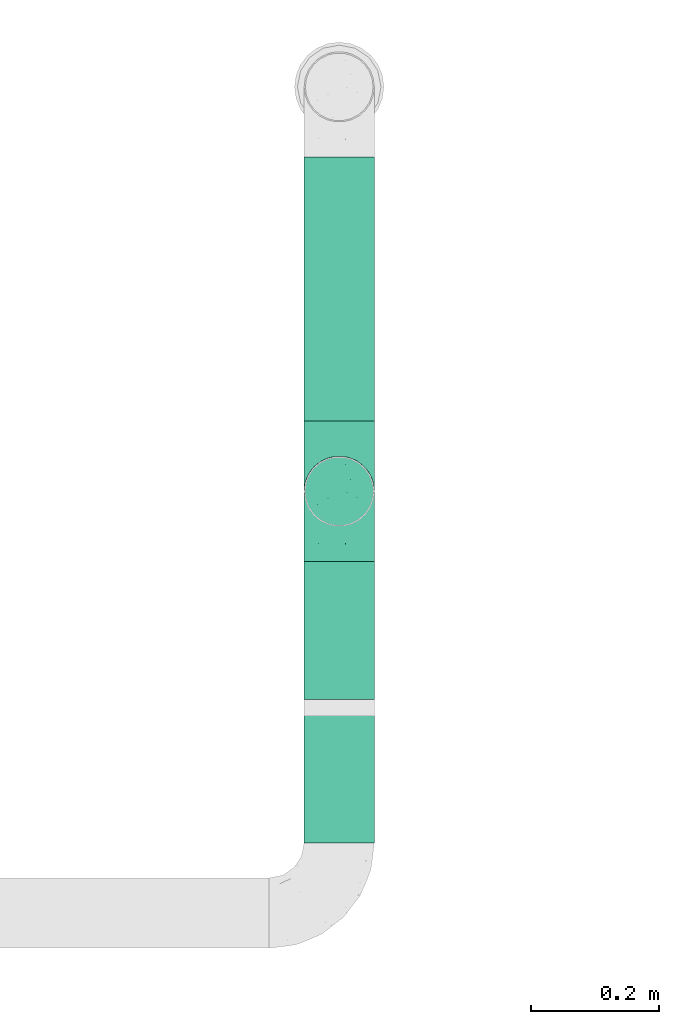
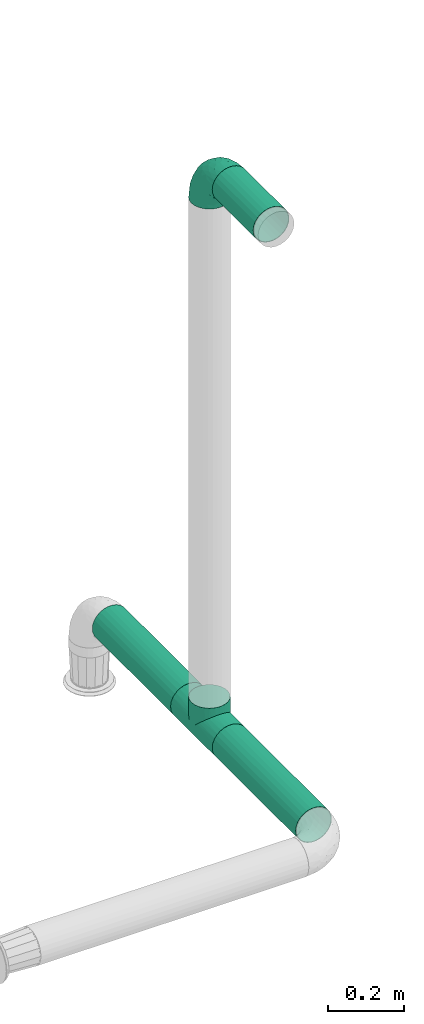
# One storey, part 90 of 103: 3 flow segments, 2 flow fittings.
"""IFC2X3 building model written with IfcOpenShell, lengths in millimetres."""

from ifc_helpers import new_model, entity, si_unit, converted_unit, derived_unit, direction, frame, origin_with_axes, origin_2d_with_axis, place, context, subcontext, project, spatial, hollow_circle, extrude, open_shell, surface_model, source, transform, mapped, material, layer, layer_set, layer_usage, type_object, element, save


model = new_model("IFC2X3")

# Units and contexts
model_context = context("Model", 3, precision=1e-05, world=origin_with_axes(), true_north=direction((0.0, 1.0)))
body_context = subcontext(model_context, "Body", "Model", "MODEL_VIEW")
ifc_project = project(units=[si_unit("AREAUNIT", "SQUARE_METRE"), si_unit("VOLUMEUNIT", "CUBIC_METRE", prefix="DECI"), si_unit("TIMEUNIT", "SECOND"), si_unit("THERMODYNAMICTEMPERATUREUNIT", "DEGREE_CELSIUS"), si_unit("PRESSUREUNIT", "PASCAL"), si_unit("MASSUNIT", "GRAM", prefix="KILO"), si_unit("LENGTHUNIT", "METRE", prefix="MILLI"), si_unit("POWERUNIT", "WATT"), si_unit("ELECTRICCURRENTUNIT", "AMPERE"), si_unit("ELECTRICVOLTAGEUNIT", "VOLT"), derived_unit("VOLUMETRICFLOWRATEUNIT", [(si_unit("VOLUMEUNIT", "CUBIC_METRE", prefix="DECI"), 1), (si_unit("TIMEUNIT", "SECOND"), -1)]), derived_unit("LINEARVELOCITYUNIT", [(si_unit("LENGTHUNIT", "METRE"), 1), (si_unit("TIMEUNIT", "SECOND"), -1)]), derived_unit("MASSDENSITYUNIT", [(si_unit("MASSUNIT", "GRAM", prefix="KILO"), 1), (si_unit("VOLUMEUNIT", "CUBIC_METRE"), -1)]), converted_unit("PLANEANGLEUNIT", "DEGREE", entity("IfcRatioMeasure", 0.01745), si_unit("PLANEANGLEUNIT", "RADIAN"), dimensions=[0, 0, 0, 0, 0, 0, 0])], contexts=[model_context])

# Site, building, storey
site_placement = place(None, origin_with_axes())
site = spatial("IfcSite", under=ifc_project, at=site_placement, CompositionType="ELEMENT")
building_placement = place(site_placement, origin_with_axes())
building = spatial("IfcBuilding", under=site, at=building_placement, Name="mc-building", CompositionType="ELEMENT")
storey_placement = place(building_placement, frame((0.0, 0.0, 5900.0), z_axis=(0.0, 0.0, 1.0), x_axis=(1.0, 0.0, 0.0)))
storey = spatial("IfcBuildingStorey", under=building, at=storey_placement, Name="3. Korrus", CompositionType="ELEMENT", Elevation=5900.0)

# Flow fitting
duct_fitting_type_1 = type_object("IfcDuctFittingType", PredefinedType="JUNCTION")
shared_shape_1 = source(origin_with_axes(), body_context, "Body", "SurfaceModel", [
    surface_model("IfcShellBasedSurfaceModel", [(0.0, -80.0, -55.0), (14.23505, -80.0, -53.12592), (-14.23505, -80.0, -53.12592), (-53.12592, -80.0, 14.23505), (-27.5, -80.0, -47.63139), (-47.63139, -80.0, -27.5), (-38.89087, -80.0, -38.89087), (55.0, -80.0, 0.0), (53.12592, -80.0, 14.23505), (38.89087, -80.0, -38.89087), (27.5, -80.0, -47.63139), (53.12592, -80.0, -14.23505), (47.63139, -80.0, -27.5), (-53.12592, -80.0, -14.23505), (-47.63139, -80.0, 27.5), (-38.89087, -80.0, 38.89087), (14.23505, -80.0, 53.12592), (-27.5, -80.0, 47.63139), (-14.23505, -80.0, 53.12592), (47.63139, -80.0, 27.5), (38.89087, -80.0, 38.89087), (27.5, -80.0, 47.63139), (0.0, -80.0, 55.0), (-55.0, -80.0, 0.0), (0.0, 0.0, 55.0), (-7.4066, -7.4066, 54.49901), (-14.74521, -14.74521, 52.98659), (-21.93978, -21.93978, 50.43457), (-28.89905, -28.89905, 46.79578), (-35.50357, -35.50357, 42.00591), (-41.58668, -41.58668, 35.99373), (-46.92319, -46.92319, 28.69171), (-51.19777, -51.19777, 20.0945), (-50.37866, -80.0, 20.86752), (-54.01174, -54.01174, 10.37938), (-55.0, -55.0, 0.0), (-54.06296, -80.0, 7.11752), (-54.01174, -54.01174, -10.37938), (-51.19777, -51.19777, -20.0945), (-54.06296, -80.0, -7.11752), (-46.92319, -46.92319, -28.69171), (-41.58668, -41.58668, -35.99373), (-50.37866, -80.0, -20.86752), (-35.50357, -35.50357, -42.00591), (-21.93978, -21.93978, -50.43457), (-14.74521, -14.74521, -52.98659), (-7.4066, -7.4066, -54.49901), (0.0, 0.0, -55.0), (-28.89905, -28.89905, -46.79578), (7.4066, -7.4066, -54.49901), (14.74521, -14.74521, -52.98659), (21.93978, -21.93978, -50.43457), (28.89905, -28.89905, -46.79578), (35.50357, -35.50357, -42.00591), (41.58668, -41.58668, -35.99373), (46.92319, -46.92319, -28.69171), (51.19777, -51.19777, -20.0945), (50.37866, -80.0, -20.86752), (54.01174, -54.01174, -10.37938), (55.0, -55.0, 0.0), (54.06296, -80.0, -7.11752), (54.01174, -54.01174, 10.37938), (51.19777, -51.19777, 20.0945), (54.06296, -80.0, 7.11752), (46.92319, -46.92319, 28.69171), (41.58668, -41.58668, 35.99373), (50.37866, -80.0, 20.86752), (35.50357, -35.50357, 42.00591), (21.93978, -21.93978, 50.43457), (14.74521, -14.74521, 52.98659), (7.4066, -7.4066, 54.49901), (28.89905, -28.89905, 46.79578), (-110.0, 0.0, -55.0), (-110.0, -14.23505, -53.12592), (-110.0, 14.23505, -53.12592), (-110.0, 53.12592, 14.23505), (-110.0, 27.5, -47.63139), (-110.0, 47.63139, -27.5), (-110.0, 38.89087, -38.89087), (-110.0, -55.0, 0.0), (-110.0, -53.12592, 14.23505), (-110.0, -38.89087, -38.89087), (-110.0, -27.5, -47.63139), (-110.0, -53.12592, -14.23505), (-110.0, -47.63139, -27.5), (-110.0, 53.12592, -14.23505), (-110.0, 47.63139, 27.5), (-110.0, 38.89087, 38.89087), (-110.0, -14.23505, 53.12592), (-110.0, 27.5, 47.63139), (-110.0, 14.23505, 53.12592), (-110.0, -47.63139, 27.5), (-110.0, -38.89087, 38.89087), (-110.0, -27.5, 47.63139), (-110.0, 0.0, 55.0), (-110.0, 55.0, 0.0), (110.0, 55.0, 0.0), (110.0, 0.0, -55.0), (110.0, 14.23505, -53.12592), (110.0, 27.5, -47.63139), (110.0, 38.89087, -38.89087), (110.0, 47.63139, -27.5), (110.0, -38.89087, -38.89087), (110.0, -53.12592, 14.23505), (110.0, -27.5, -47.63139), (110.0, -14.23505, -53.12592), (110.0, -47.63139, -27.5), (110.0, -53.12592, -14.23505), (110.0, -55.0, 0.0), (110.0, 53.12592, -14.23505), (110.0, 53.12592, 14.23505), (110.0, 47.63139, 27.5), (110.0, 38.89087, 38.89087), (110.0, 0.0, 55.0), (110.0, 27.5, 47.63139), (110.0, 14.23505, 53.12592), (110.0, -47.63139, 27.5), (110.0, -38.89087, 38.89087), (110.0, -27.5, 47.63139), (110.0, -14.23505, 53.12592)], [open_shell([[[0, 1, 2]], [[2, 3, 4]], [[5, 6, 3]], [[6, 4, 3]], [[2, 7, 8]], [[9, 7, 10]], [[1, 10, 7]], [[11, 7, 12]], [[9, 12, 7]], [[7, 2, 1]], [[5, 3, 13]], [[2, 14, 3]], [[2, 15, 14]], [[2, 16, 17]], [[17, 15, 2]], [[16, 18, 17]], [[2, 8, 19]], [[2, 19, 20]], [[2, 20, 21]], [[16, 2, 21]], [[16, 22, 18]], [[23, 13, 3]], [[24, 25, 22]], [[26, 27, 18]], [[25, 26, 18]], [[22, 25, 18]], [[17, 28, 29]], [[17, 18, 27]], [[17, 29, 15]], [[28, 17, 27]], [[30, 31, 14]], [[32, 3, 33]], [[32, 34, 3]], [[35, 36, 34]], [[31, 32, 14]], [[15, 30, 14]], [[34, 36, 3]], [[33, 14, 32]], [[36, 35, 23]], [[30, 15, 29]], [[37, 38, 13]], [[37, 13, 39]], [[40, 41, 5]], [[38, 5, 42]], [[38, 40, 5]], [[37, 39, 35]], [[35, 39, 23]], [[13, 38, 42]], [[41, 6, 5]], [[41, 43, 6]], [[44, 45, 2]], [[46, 47, 0]], [[45, 46, 2]], [[43, 48, 4]], [[44, 4, 48]], [[44, 2, 4]], [[46, 0, 2]], [[43, 4, 6]], [[47, 49, 0]], [[50, 51, 1]], [[49, 50, 1]], [[0, 49, 1]], [[10, 52, 53]], [[10, 1, 51]], [[10, 53, 9]], [[52, 10, 51]], [[54, 55, 12]], [[56, 11, 57]], [[56, 58, 11]], [[59, 60, 58]], [[55, 56, 12]], [[9, 54, 12]], [[58, 60, 11]], [[57, 12, 56]], [[60, 59, 7]], [[54, 9, 53]], [[61, 62, 8]], [[61, 8, 63]], [[64, 65, 19]], [[62, 19, 66]], [[62, 64, 19]], [[61, 63, 59]], [[7, 59, 63]], [[62, 66, 8]], [[65, 20, 19]], [[65, 67, 20]], [[68, 69, 16]], [[70, 24, 22]], [[69, 70, 16]], [[67, 71, 21]], [[68, 21, 71]], [[68, 16, 21]], [[70, 22, 16]], [[67, 21, 20]], [[72, 73, 74]], [[74, 75, 76]], [[77, 78, 75]], [[76, 75, 78]], [[74, 79, 80]], [[81, 79, 82]], [[73, 82, 79]], [[83, 79, 84]], [[81, 84, 79]], [[79, 74, 73]], [[77, 75, 85]], [[74, 86, 75]], [[74, 87, 86]], [[74, 88, 89]], [[89, 87, 74]], [[88, 90, 89]], [[74, 91, 92]], [[91, 74, 80]], [[92, 93, 74]], [[74, 93, 88]], [[88, 94, 90]], [[95, 85, 75]], [[96, 97, 98]], [[99, 96, 98]], [[96, 100, 101]], [[100, 96, 99]], [[102, 97, 103]], [[97, 102, 104]], [[104, 105, 97]], [[102, 103, 106]], [[106, 103, 107]], [[108, 107, 103]], [[109, 96, 101]], [[110, 111, 97]], [[97, 111, 112]], [[113, 97, 114]], [[97, 112, 114]], [[113, 114, 115]], [[116, 103, 97]], [[117, 116, 97]], [[118, 117, 97]], [[119, 118, 97]], [[119, 97, 113]], [[96, 110, 97]], [[24, 113, 115]], [[89, 115, 114]], [[94, 24, 90]], [[90, 24, 115]], [[115, 89, 90]], [[114, 87, 89]], [[86, 112, 111]], [[75, 111, 110]], [[95, 110, 96]], [[87, 112, 86]], [[86, 111, 75]], [[110, 95, 75]], [[112, 87, 114]], [[85, 96, 109]], [[77, 109, 101]], [[95, 96, 85]], [[85, 109, 77]], [[101, 78, 77]], [[101, 100, 78]], [[76, 100, 99]], [[74, 99, 98]], [[47, 98, 97]], [[76, 99, 74]], [[47, 72, 74]], [[98, 47, 74]], [[100, 76, 78]], [[47, 46, 72]], [[45, 44, 73]], [[46, 45, 73]], [[72, 46, 73]], [[82, 48, 43]], [[82, 73, 44]], [[82, 43, 81]], [[48, 82, 44]], [[41, 40, 84]], [[38, 37, 83]], [[40, 38, 84]], [[81, 41, 84]], [[37, 79, 83]], [[83, 84, 38]], [[79, 37, 35]], [[41, 81, 43]], [[49, 97, 105]], [[105, 104, 51]], [[53, 104, 102]], [[53, 52, 104]], [[49, 47, 97]], [[51, 50, 105]], [[52, 51, 104]], [[49, 105, 50]], [[54, 102, 106]], [[56, 106, 107]], [[58, 107, 108]], [[55, 54, 106]], [[58, 56, 107]], [[59, 58, 108]], [[55, 106, 56]], [[102, 54, 53]], [[34, 32, 80]], [[31, 30, 91]], [[32, 31, 91]], [[35, 34, 79]], [[80, 79, 34]], [[32, 91, 80]], [[30, 92, 91]], [[30, 29, 92]], [[27, 26, 88]], [[25, 24, 94]], [[26, 25, 88]], [[29, 28, 93]], [[27, 93, 28]], [[27, 88, 93]], [[25, 94, 88]], [[29, 93, 92]], [[61, 108, 103]], [[62, 103, 116]], [[65, 116, 117]], [[61, 59, 108]], [[64, 62, 116]], [[65, 64, 116]], [[61, 103, 62]], [[117, 67, 65]], [[71, 67, 118]], [[118, 67, 117]], [[68, 118, 119]], [[70, 119, 113]], [[68, 71, 118]], [[70, 69, 119]], [[24, 70, 113]], [[68, 119, 69]]])]),
])
flow_fitting_1_placement = place(storey_placement, frame((33781.67179, 4097.31763, 2345.0), z_axis=(-1.0, 0.0, 0.0), x_axis=(0.0, 1.0, 0.0)))
element("IfcFlowFitting", 1, at=flow_fitting_1_placement, inside=storey, type_object=duct_fitting_type_1, context=body_context, shape_type="MappedRepresentation", body=[
    mapped(shared_shape_1, transform((0.0, 0.0, 0.0), scale=1.0)),
])

# Flow segments
ifc_material = material(Name="FZ1")
ifc_layer = layer(ifc_material, 0.0)
ifc_layer_set = layer_set([ifc_layer], Name="FZ1")
ifc_layer_usage = layer_usage(ifc_layer_set, "AXIS1", "POSITIVE", 0.0)
duct_segment_type = type_object("IfcDuctSegmentType", Name="Safe", PredefinedType="RIGIDSEGMENT")
shared_shape_2 = source(origin_with_axes(), body_context, "Body", "SweptSolid", [
    extrude(hollow_circle(Radius=55.0, WallThickness=2.0, at=origin_2d_with_axis()), frame((0.0, 0.0, 0.0), z_axis=(1.0, 0.0, 0.0), x_axis=(0.0, 1.0, 0.0)), (0.0, 0.0, 1.0), 413.5),
])
flow_segment_1_placement = place(storey_placement, frame((33781.67179, 4207.31763, 2345.0), z_axis=(0.0, 0.0, 1.0), x_axis=(0.0, 1.0, 0.0)))
element("IfcFlowSegment", 2, at=flow_segment_1_placement, inside=storey, type_object=duct_segment_type, material=ifc_layer_usage, Name="Safe", context=body_context, shape_type="MappedRepresentation", body=[
    mapped(shared_shape_2, transform((0.0, 0.0, 0.0), scale=1.0)),
])
shared_shape_3 = source(origin_with_axes(), body_context, "Body", "SweptSolid", [
    extrude(hollow_circle(Radius=55.0, WallThickness=2.0, at=origin_2d_with_axis()), frame((0.0, 0.0, 0.0), z_axis=(1.0, 0.0, 0.0), x_axis=(0.0, 1.0, 0.0)), (0.0, 0.0, 1.0), 440.5),
])
flow_segment_2_placement = place(storey_placement, frame((33781.67179, 3546.80698, 2345.0), z_axis=(0.0, 0.0, 1.0), x_axis=(0.0, 1.0, 0.0)))
element("IfcFlowSegment", 3, at=flow_segment_2_placement, inside=storey, type_object=duct_segment_type, material=ifc_layer_usage, Name="Safe", context=body_context, shape_type="MappedRepresentation", body=[
    mapped(shared_shape_3, transform((0.0, 0.0, 0.0), scale=1.0)),
])
shared_shape_4 = source(origin_with_axes(), body_context, "Body", "SweptSolid", [
    extrude(hollow_circle(Radius=55.0, WallThickness=2.0, at=origin_2d_with_axis()), frame((0.0, 0.0, 0.0), z_axis=(1.0, 0.0, 0.0), x_axis=(0.0, 1.0, 0.0)), (0.0, 0.0, 1.0), 216.1),
])
flow_segment_3_placement = place(storey_placement, frame((33781.67179, 3771.20513, 4144.0), z_axis=(0.0, 0.0, 1.0), x_axis=(0.0, 1.0, 0.0)))
element("IfcFlowSegment", 4, at=flow_segment_3_placement, inside=storey, type_object=duct_segment_type, material=ifc_layer_usage, Name="Safe", context=body_context, shape_type="MappedRepresentation", body=[
    mapped(shared_shape_4, transform((0.0, 0.0, 0.0), scale=1.0)),
])

# Flow fitting
duct_fitting_type_2 = type_object("IfcDuctFittingType", Name="BU", PredefinedType="BEND")
shared_shape_5 = source(origin_with_axes(), body_context, "Body", "SurfaceModel", [
    surface_model("IfcShellBasedSurfaceModel", [(-110.0, 0.0, -55.0), (-110.0, -14.23505, -53.12592), (-110.0, 14.23505, -53.12592), (-110.0, 53.12592, 14.23505), (-110.0, 27.5, -47.63139), (-110.0, 38.89087, -38.89087), (-110.0, -55.0, 0.0), (-110.0, -53.12592, 14.23505), (-110.0, -38.89087, -38.89087), (-110.0, -27.5, -47.63139), (-110.0, -53.12592, -14.23505), (-110.0, -47.63139, -27.5), (-110.0, -14.23505, 53.12592), (-110.0, 14.23505, 53.12592), (-110.0, 27.5, 47.63139), (-110.0, -47.63139, 27.5), (-110.0, -38.89087, 38.89087), (-110.0, -27.5, 47.63139), (-110.0, 0.0, 55.0), (-110.0, 55.0, 0.0), (-110.0, 53.12592, -14.23505), (-110.0, 47.63139, -27.5), (-110.0, 47.63139, 27.5), (-110.0, 38.89087, 38.89087), (-14.23505, 110.0, -53.12592), (-55.0, 110.0, 0.0), (0.0, 110.0, -55.0), (-27.5, 110.0, -47.63139), (-38.89087, 110.0, -38.89087), (-47.63139, 110.0, -27.5), (38.89087, 110.0, -38.89087), (53.12592, 110.0, 14.23505), (27.5, 110.0, -47.63139), (14.23505, 110.0, -53.12592), (47.63139, 110.0, -27.5), (53.12592, 110.0, -14.23505), (55.0, 110.0, 0.0), (-53.12592, 110.0, -14.23505), (-53.12592, 110.0, 14.23505), (-47.63139, 110.0, 27.5), (-38.89087, 110.0, 38.89087), (-27.5, 110.0, 47.63139), (0.0, 110.0, 55.0), (-14.23505, 110.0, 53.12592), (38.89087, 110.0, 38.89087), (47.63139, 110.0, 27.5), (27.5, 110.0, 47.63139), (14.23505, 110.0, 53.12592), (-64.21732, 48.68956, 43.63444), (-76.6405, 38.18013, 45.55988), (-60.44912, 32.56953, 51.94617), (-76.00813, 5.38378, 55.0), (-90.15553, 11.94394, 54.09138), (-78.5998, 26.77405, 50.81338), (-70.18771, 18.55163, 54.03432), (-75.55424, 54.2118, 32.41257), (-93.27622, 45.77614, 33.48188), (-96.12334, 22.13664, 50.81337), (-21.00813, 45.34362, 55.0), (-18.36258, 70.48427, 54.04484), (-32.04182, 59.64019, 52.24446), (-63.88653, 74.77858, 17.99134), (-74.66383, 63.08407, 19.92123), (-63.60674, 66.07878, 29.97482), (-99.597, 52.72185, 18.52927), (-93.11138, 56.59448, 10.50359), (-98.21577, 57.34403, 0.0), (-53.42855, 92.60092, 21.04759), (-88.54852, 54.8376, 21.04759), (-11.86161, 90.23965, 54.10313), (-5.38378, 76.00813, 55.0), (-57.34403, 98.21577, 0.0), (-56.64619, 93.12774, 10.22088), (-45.34362, 21.00813, 55.0), (-44.60838, 44.60838, 52.13415), (-92.68484, 35.46673, 43.63443), (-22.25266, 95.40765, 50.81337), (-35.97783, 90.61597, 43.63443), (-43.70931, 69.58671, 44.47149), (-27.23711, 77.39884, 50.81337), (-57.2828, 79.3123, 24.9774), (-58.67786, 84.31125, 16.04456), (-82.93277, 60.36161, 12.91784), (-49.88337, 54.51816, 47.224), (-74.57753, 66.83759, 9.55742), (-45.35812, 94.97281, 33.48188), (-59.18663, 88.95241, 0.0), (-51.517, 78.6292, 33.48188), (-65.14788, 80.03077, 0.0), (-56.45322, 62.06476, 39.63545), (-88.95241, 59.18663, 0.0), (-71.10913, 71.10913, 0.0), (-80.03077, 65.14788, 0.0), (-94.9309, 45.36788, -33.48188), (-93.11358, 56.60141, -10.46614), (-99.64997, 52.79499, -18.30015), (-90.20425, 36.08686, -43.63443), (-79.99933, 46.56772, -37.92748), (-76.00813, 5.38378, -55.0), (-72.75364, 19.68651, -53.60527), (-45.34362, 21.00813, -55.0), (-21.91957, 65.12078, -53.85897), (-5.38378, 76.00813, -55.0), (-21.00813, 45.34362, -55.0), (-35.41876, 92.89265, -43.63443), (-91.10309, 11.02766, -54.21832), (-45.77614, 93.27622, -33.48188), (-90.50474, 23.21022, -50.81337), (-70.92854, 33.31794, -49.51754), (-78.52933, 63.35627, -11.73997), (-24.91508, 84.05606, -50.81337), (-88.78941, 54.74452, -21.04759), (-69.59921, 57.34866, -33.48187), (-73.36422, 62.46673, -22.94182), (-63.49062, 67.59111, -28.46929), (-56.59448, 93.11138, -10.50359), (-54.8376, 88.54852, -21.04759), (-54.10679, 75.85581, -32.31867), (-57.75956, 31.09612, -52.80882), (-52.72185, 99.597, -18.52927), (-12.62913, 89.46304, -53.99097), (-34.46825, 66.46123, -50.04329), (-43.9837, 43.9837, -52.42279), (-65.78527, 72.58348, -17.68796), (-70.34468, 43.65295, -44.21951), (-57.47001, 51.99467, -44.91465), (-60.72547, 82.29174, -12.88567), (-42.34915, 74.24548, -43.63444), (-57.25194, 63.5016, -38.08211), (-80.95344, 53.56991, -29.32027), (-52.32891, 4.55257, -54.0482), (32.52942, 47.13398, -30.48571), (14.88266, 20.92917, -33.7947), (14.95561, 36.05775, -42.26543), (30.24048, 70.09027, -41.7461), (19.3559, 65.35825, -48.00507), (-70.35075, -46.44478, -19.5952), (-47.13398, -32.52942, -30.48571), (-28.49299, -30.5778, -16.4009), (-4.55257, 52.32891, -54.0482), (-22.4954, 22.4954, -53.25347), (-75.47368, -11.22546, -52.60718), (-81.32209, -51.5606, -9.98467), (-80.81763, -41.84862, -32.14655), (-70.09027, -30.24048, -41.7461), (-36.05774, -14.95561, -42.26543), (-9.15831, -10.852, -27.8997), (-65.35825, -19.3559, -48.00507), (11.22546, 75.47368, -52.60718), (3.94376, 43.9333, -50.53315), (-13.39742, 13.39743, -48.13058), (-43.9333, -3.94376, -50.53315), (49.37776, 67.29486, 0.0), (41.8609, 47.82256, -9.92641), (50.20582, 74.51695, -9.9731), (18.93131, 11.7156, -17.56239), (-27.5, -32.89419, 0.0), (-1.23348, -12.25375, -12.18106), (41.84862, 80.81763, -32.14655), (35.70604, 41.31408, -20.38235), (46.44478, 70.35075, -19.5952), (32.89419, 27.5, 0.0), (6.67262, -6.67262, 0.0), (-67.29486, -49.37776, 0.0), (-50.36265, -42.95545, -9.51562), (-5.47251, 5.47251, -39.92906), (-70.35075, -46.44478, 19.5952), (-74.51695, -50.20582, 9.9731), (-41.31407, -35.70604, 20.38235), (-47.13398, -32.52942, 30.48571), (-80.81763, -41.84862, 32.14655), (-4.55257, 52.32891, 54.0482), (11.22546, 75.47368, 52.60718), (-43.9333, -3.94376, 50.53315), (-65.35825, -19.3559, 48.00507), (-36.05774, -14.95561, 42.26543), (-70.09027, -30.24048, 41.7461), (-11.7156, -18.93131, 17.56239), (30.5778, 28.49299, 16.4009), (12.25375, 1.23348, 12.18106), (51.5606, 81.32209, 9.98467), (42.95545, 50.36265, 9.51562), (-75.47368, -11.22546, 52.60718), (-52.32891, 4.55257, 54.0482), (3.94376, 43.9333, 50.53315), (-22.4954, 22.4954, 53.25347), (-13.39742, 13.39743, 48.13058), (10.852, 9.15831, 27.8997), (-20.92916, -14.88266, 33.79469), (-47.82256, -41.8609, 9.92641), (32.52942, 47.13398, 30.48571), (46.44478, 70.35075, 19.5952), (41.84862, 80.81763, 32.14655), (30.24048, 70.09027, 41.7461), (19.3559, 65.35825, 48.00507), (14.95561, 36.05775, 42.26543), (-5.47251, 5.47251, 39.92906)], [open_shell([[[0, 1, 2]], [[2, 3, 4]], [[4, 3, 5]], [[2, 6, 7]], [[8, 6, 9]], [[1, 9, 6]], [[10, 6, 11]], [[8, 11, 6]], [[6, 2, 1]], [[12, 13, 14]], [[15, 2, 7]], [[16, 17, 2]], [[2, 17, 12]], [[12, 18, 13]], [[19, 20, 3]], [[5, 3, 21]], [[20, 21, 3]], [[22, 3, 2]], [[23, 22, 2]], [[12, 14, 2]], [[2, 14, 23]], [[15, 16, 2]], [[24, 25, 26]], [[27, 25, 24]], [[25, 28, 29]], [[28, 25, 27]], [[30, 26, 31]], [[26, 30, 32]], [[32, 33, 26]], [[34, 31, 35]], [[31, 34, 30]], [[35, 31, 36]], [[29, 37, 25]], [[38, 39, 26]], [[39, 40, 26]], [[41, 42, 40]], [[42, 26, 40]], [[42, 41, 43]], [[26, 44, 45]], [[31, 26, 45]], [[26, 46, 44]], [[47, 46, 26]], [[42, 47, 26]], [[25, 38, 26]], [[48, 49, 50]], [[18, 51, 52]], [[53, 54, 50]], [[55, 56, 49]], [[56, 22, 23]], [[13, 57, 14]], [[58, 59, 60]], [[61, 62, 63]], [[3, 64, 65]], [[53, 52, 54]], [[3, 65, 66]], [[67, 39, 38]], [[56, 68, 64]], [[65, 64, 68]], [[69, 59, 70]], [[38, 71, 72]], [[73, 58, 74]], [[75, 49, 56]], [[76, 69, 43]], [[53, 57, 52]], [[77, 78, 79]], [[41, 76, 43]], [[43, 69, 42]], [[55, 68, 56]], [[23, 14, 75]], [[76, 77, 79]], [[80, 67, 81]], [[62, 82, 68]], [[60, 78, 83]], [[62, 84, 82]], [[85, 77, 40]], [[81, 67, 72]], [[86, 72, 71]], [[87, 85, 67]], [[61, 81, 88]], [[77, 41, 40]], [[78, 77, 87]], [[23, 75, 56]], [[83, 89, 48]], [[85, 40, 39]], [[62, 68, 55]], [[89, 87, 63]], [[83, 48, 50]], [[57, 75, 14]], [[49, 75, 53]], [[67, 85, 39]], [[87, 77, 85]], [[63, 62, 55]], [[89, 55, 48]], [[80, 63, 87]], [[66, 65, 90]], [[66, 19, 3]], [[84, 91, 92]], [[92, 90, 82]], [[65, 82, 90]], [[61, 84, 62]], [[92, 82, 84]], [[68, 82, 65]], [[3, 22, 64]], [[56, 64, 22]], [[38, 25, 71]], [[81, 72, 86]], [[38, 72, 67]], [[91, 61, 88]], [[80, 81, 61]], [[63, 80, 61]], [[67, 80, 87]], [[77, 76, 41]], [[79, 59, 69]], [[79, 69, 76]], [[42, 69, 70]], [[60, 59, 79]], [[58, 70, 59]], [[78, 60, 79]], [[58, 60, 74]], [[52, 57, 13]], [[75, 57, 53]], [[18, 52, 13]], [[52, 51, 54]], [[51, 73, 54]], [[50, 73, 74]], [[73, 50, 54]], [[50, 74, 83]], [[60, 83, 74]], [[89, 83, 78]], [[87, 89, 78]], [[55, 89, 63]], [[50, 49, 53]], [[55, 49, 48]], [[81, 86, 88]], [[91, 84, 61]], [[5, 21, 93]], [[90, 94, 66]], [[20, 94, 95]], [[96, 93, 97]], [[98, 99, 100]], [[96, 4, 5]], [[101, 102, 103]], [[28, 27, 104]], [[2, 105, 0]], [[104, 106, 28]], [[99, 105, 107]], [[108, 107, 96]], [[90, 109, 94]], [[107, 2, 4]], [[20, 66, 94]], [[27, 24, 110]], [[109, 111, 94]], [[112, 113, 114]], [[37, 115, 71]], [[116, 106, 117]], [[99, 118, 100]], [[116, 115, 119]], [[37, 119, 115]], [[24, 120, 110]], [[121, 110, 101]], [[119, 106, 116]], [[101, 110, 120]], [[122, 103, 100]], [[117, 123, 116]], [[124, 125, 108]], [[115, 116, 126]], [[106, 29, 28]], [[26, 102, 120]], [[127, 104, 110]], [[97, 124, 96]], [[125, 122, 118]], [[128, 127, 125]], [[96, 5, 93]], [[115, 126, 86]], [[117, 106, 127]], [[111, 113, 129]], [[95, 93, 21]], [[97, 129, 112]], [[110, 104, 27]], [[106, 104, 127]], [[96, 107, 4]], [[99, 107, 108]], [[99, 108, 118]], [[105, 99, 98]], [[112, 114, 128]], [[121, 125, 127]], [[20, 19, 66]], [[109, 90, 92]], [[94, 111, 95]], [[91, 123, 109]], [[129, 113, 112]], [[93, 95, 111]], [[21, 20, 95]], [[71, 115, 86]], [[71, 25, 37]], [[123, 91, 88]], [[126, 116, 123]], [[123, 88, 126]], [[86, 126, 88]], [[37, 29, 119]], [[106, 119, 29]], [[129, 93, 111]], [[124, 112, 125]], [[0, 105, 98]], [[107, 105, 2]], [[125, 118, 108]], [[100, 118, 122]], [[93, 129, 97]], [[113, 111, 109]], [[109, 123, 113]], [[114, 123, 117]], [[123, 114, 113]], [[128, 114, 117]], [[127, 128, 117]], [[112, 128, 125]], [[103, 122, 101]], [[110, 121, 127]], [[101, 122, 121]], [[125, 121, 122]], [[26, 120, 24]], [[101, 120, 102]], [[96, 124, 108]], [[92, 91, 109]], [[112, 124, 97]], [[100, 130, 98]], [[131, 132, 133]], [[32, 134, 135]], [[136, 137, 138]], [[139, 140, 103]], [[98, 141, 0]], [[142, 10, 136]], [[143, 144, 137]], [[6, 10, 142]], [[137, 145, 146]], [[144, 147, 145]], [[143, 136, 11]], [[11, 136, 10]], [[8, 143, 11]], [[148, 149, 139]], [[8, 9, 144]], [[9, 1, 147]], [[130, 141, 98]], [[103, 140, 100]], [[148, 135, 149]], [[150, 151, 140]], [[152, 153, 154]], [[130, 140, 151]], [[148, 26, 33]], [[147, 1, 141]], [[155, 146, 132]], [[156, 138, 157]], [[134, 30, 158]], [[150, 140, 149]], [[158, 30, 34]], [[30, 134, 32]], [[153, 159, 160]], [[131, 160, 159]], [[144, 145, 137]], [[36, 152, 154]], [[146, 138, 137]], [[155, 161, 162]], [[158, 160, 131]], [[133, 149, 135]], [[156, 163, 164]], [[163, 142, 164]], [[139, 103, 102]], [[153, 152, 161]], [[34, 35, 160]], [[162, 157, 155]], [[132, 165, 133]], [[157, 146, 155]], [[140, 130, 100]], [[141, 130, 151]], [[141, 151, 147]], [[141, 1, 0]], [[102, 26, 148]], [[140, 139, 149]], [[102, 148, 139]], [[135, 33, 32]], [[151, 150, 145]], [[9, 147, 144]], [[151, 145, 147]], [[145, 165, 146]], [[135, 148, 33]], [[133, 135, 134]], [[131, 133, 134]], [[133, 165, 150]], [[133, 150, 149]], [[145, 150, 165]], [[132, 131, 159]], [[146, 165, 132]], [[160, 158, 34]], [[134, 158, 131]], [[144, 143, 8]], [[136, 143, 137]], [[155, 153, 161]], [[154, 153, 160]], [[153, 155, 159]], [[132, 159, 155]], [[160, 35, 154]], [[36, 154, 35]], [[164, 136, 138]], [[6, 142, 163]], [[136, 164, 142]], [[156, 164, 138]], [[156, 157, 162]], [[146, 157, 138]], [[15, 7, 166]], [[6, 163, 167]], [[168, 169, 166]], [[166, 169, 170]], [[171, 172, 70]], [[173, 174, 175]], [[17, 176, 174]], [[177, 156, 162]], [[176, 16, 170]], [[170, 16, 15]], [[161, 178, 179]], [[152, 180, 181]], [[182, 173, 183]], [[18, 12, 182]], [[184, 185, 186]], [[183, 185, 73]], [[183, 73, 51]], [[177, 187, 188]], [[189, 168, 166]], [[187, 178, 190]], [[16, 176, 17]], [[161, 152, 181]], [[45, 191, 31]], [[45, 44, 192]], [[192, 191, 45]], [[180, 36, 31]], [[193, 194, 195]], [[46, 47, 194]], [[193, 195, 190]], [[193, 44, 46]], [[172, 42, 70]], [[185, 58, 73]], [[189, 163, 156]], [[163, 189, 167]], [[70, 58, 171]], [[184, 171, 185]], [[169, 188, 175]], [[180, 31, 191]], [[192, 193, 190]], [[191, 190, 178]], [[182, 174, 173]], [[194, 47, 172]], [[190, 195, 187]], [[186, 185, 173]], [[162, 179, 177]], [[188, 196, 175]], [[179, 187, 177]], [[185, 171, 58]], [[172, 171, 184]], [[172, 184, 194]], [[172, 47, 42]], [[51, 18, 182]], [[185, 183, 173]], [[51, 182, 183]], [[174, 12, 17]], [[184, 186, 195]], [[46, 194, 193]], [[184, 195, 194]], [[195, 196, 187]], [[174, 182, 12]], [[175, 174, 176]], [[169, 175, 176]], [[175, 196, 186]], [[175, 186, 173]], [[195, 186, 196]], [[188, 169, 168]], [[187, 196, 188]], [[166, 170, 15]], [[176, 170, 169]], [[193, 192, 44]], [[191, 192, 190]], [[177, 189, 156]], [[167, 189, 166]], [[189, 177, 168]], [[188, 168, 177]], [[166, 7, 167]], [[6, 167, 7]], [[181, 191, 178]], [[36, 180, 152]], [[191, 181, 180]], [[161, 181, 178]], [[161, 179, 162]], [[187, 179, 178]]])]),
])
flow_fitting_2_placement = place(storey_placement, frame((33781.67179, 4097.31763, 4144.0), z_axis=(1.0, 0.0, 0.0), x_axis=(0.0, 0.0, 1.0)))
element("IfcFlowFitting", 5, at=flow_fitting_2_placement, inside=storey, type_object=duct_fitting_type_2, Name="BU", context=body_context, shape_type="MappedRepresentation", body=[
    mapped(shared_shape_5, transform((0.0, 0.0, 0.0), scale=1.0)),
])

save(model, "model.ifc")
